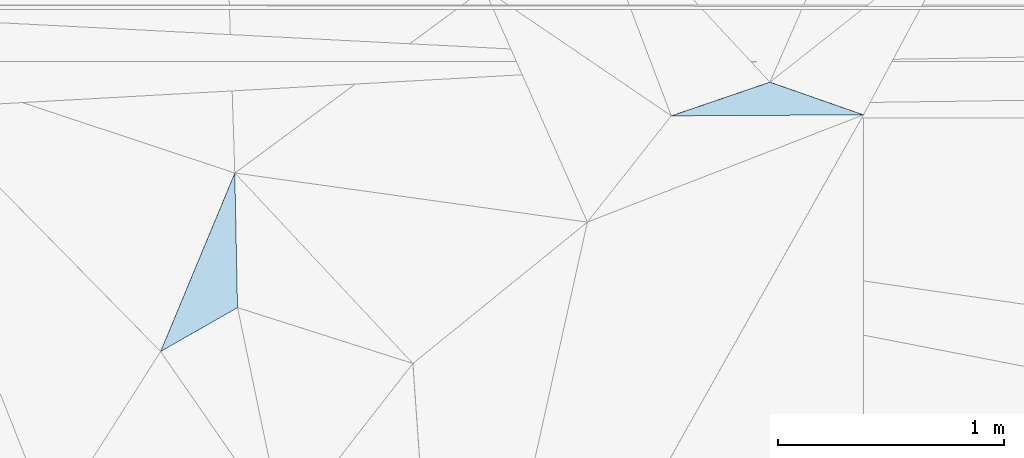
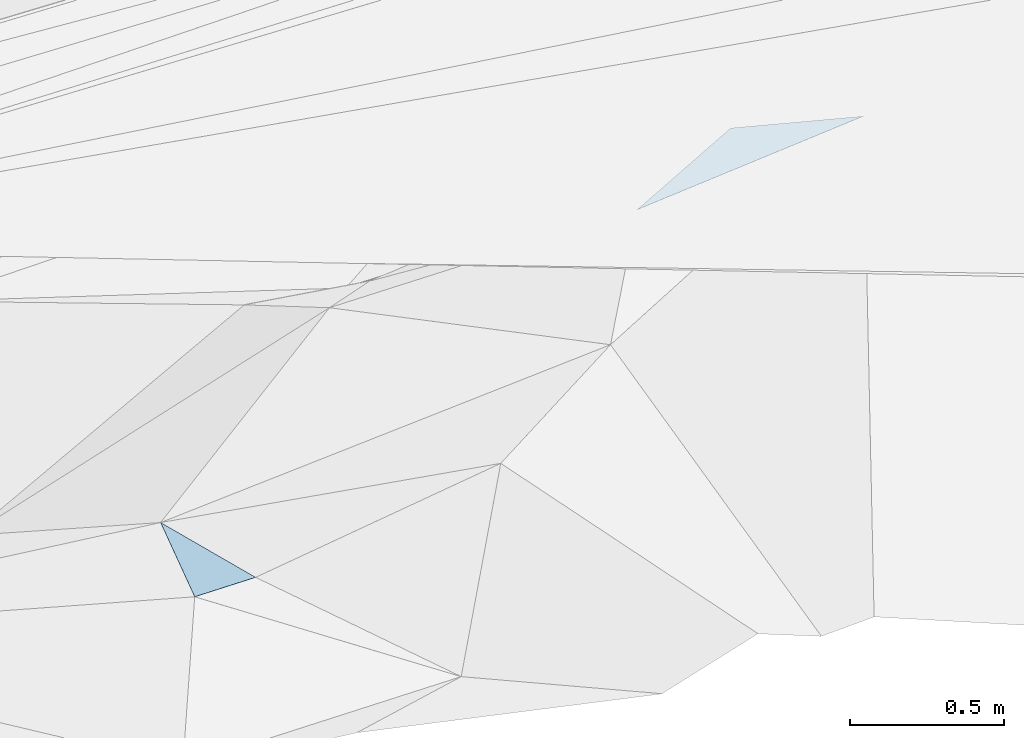
# One storey, part 182 of 275: 2 plates.
"""IFC2X3 building model written with IfcOpenShell, lengths in millimetres."""

from ifc_helpers import new_model, si_unit, frame, origin_with_axes, place, context, subcontext, project, spatial, polyline, outline, extrude, material, type_object, element, save


model = new_model("IFC2X3")

# Units and contexts
model_context = context("Model", 3, precision=1e-05, world=origin_with_axes())
body_context = subcontext(model_context, "Body", "Model", "MODEL_VIEW")
ifc_project = project(units=[si_unit("LENGTHUNIT", "METRE", prefix="MILLI"), si_unit("AREAUNIT", "SQUARE_METRE"), si_unit("VOLUMEUNIT", "CUBIC_METRE"), si_unit("MASSUNIT", "GRAM", prefix="KILO"), si_unit("TIMEUNIT", "SECOND"), si_unit("PLANEANGLEUNIT", "RADIAN"), si_unit("SOLIDANGLEUNIT", "STERADIAN"), si_unit("THERMODYNAMICTEMPERATUREUNIT", "DEGREE_CELSIUS"), si_unit("LUMINOUSINTENSITYUNIT", "LUMEN")], contexts=[model_context])

# Site, building, storey
site_placement = place(None, origin_with_axes())
site = spatial("IfcSite", under=ifc_project, at=site_placement, CompositionType="ELEMENT")
building_placement = place(site_placement, origin_with_axes())
building = spatial("IfcBuilding", under=site, at=building_placement, Name="Undefined", CompositionType="ELEMENT")
storey_placement = place(building_placement, origin_with_axes())
storey = spatial("IfcBuildingStorey", under=building, at=storey_placement, Name="Undefined", CompositionType="ELEMENT", Elevation=0.0)

# Plates
ifc_material = material()
plate_type_1 = type_object("IfcPlateType", PredefinedType="NOTDEFINED")
plate_1_placement = place(storey_placement, frame((-30052.5264106363, 66048.6505469811, 46809.5224286728), z_axis=(0.0770910808336832, 0.285982631298519, -0.955128734700967), x_axis=(0.932307022618265, 0.318841210484289, 0.170715840136698)))
element("IfcPlate", 1, at=plate_1_placement, inside=storey, type_object=plate_type_1, material=ifc_material, Name="00", context=body_context, shape_type="SweptSolid", body=[
    extrude(outline(polyline([(0.0, 0.0), (468.614990234375, -1.94995664060116e-09), (806.63232421875, 279.721771240234), (0.0, 0.0)])), frame((-8.85201319254618e-08, 2.18876761149539e-07, -0.5000001331573), z_axis=(0.0, 0.0, 1.0), x_axis=(1.0, 0.0, 0.0)), (0.0, 0.0, 1.0), 1.0),
])
plate_type_2 = type_object("IfcPlateType", PredefinedType="NOTDEFINED")
plate_2_placement = place(storey_placement, frame((-31985.4228958575, 65795.3072291979, 46399.5374677716), z_axis=(-0.307146814035045, -0.223480516839868, -0.925049886882382), x_axis=(0.0196438155484442, -0.973317755794276, 0.22861904287765)))
element("IfcPlate", 2, at=plate_2_placement, inside=storey, type_object=plate_type_2, material=ifc_material, Name="00", context=body_context, shape_type="SweptSolid", body=[
    extrude(outline(polyline([(0.0, 0.0), (612.372436523438, -1.229636836797e-09), (831.356811523438, 362.416656494141), (0.0, 0.0)])), frame((-8.85201319254618e-08, 2.18876761149539e-07, -0.5000001331573), z_axis=(0.0, 0.0, 1.0), x_axis=(1.0, 0.0, 0.0)), (0.0, 0.0, 1.0), 1.0),
])

save(model, "model.ifc")
